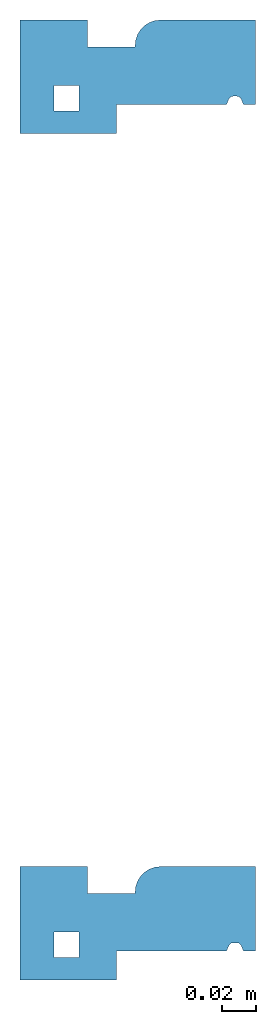
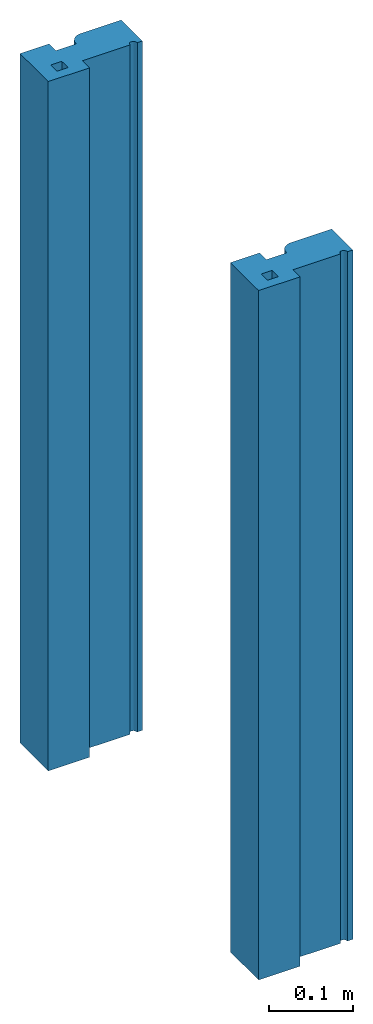
# One storey: 2 columns.
"""IFC4 building model written with IfcOpenShell, lengths in millimetres."""

from ifc_helpers import new_model, entity, si_unit, converted_unit, frame, origin_with_axes, origin_2d_with_axis, place, context, subcontext, project, spatial, line, arc, indexed_curve, outline, extrude, material, material_profile, profile_set, profile_usage, type_object, element, save


model = new_model("IFC4")

# Units and contexts
model_context = context("Model", 3, precision=1e-05, world=origin_with_axes())
plan_context = context("Plan", 2, precision=1e-05, world=origin_2d_with_axis())
body_context = subcontext(model_context, "Body", "Model", "MODEL_VIEW")
ifc_project = project(units=[converted_unit("PLANEANGLEUNIT", "degree", entity("IfcReal", 0.0174532925199433), si_unit("PLANEANGLEUNIT", "RADIAN"), dimensions=[0, 0, 0, 0, 0, 0, 0]), si_unit("AREAUNIT", "SQUARE_METRE"), si_unit("VOLUMEUNIT", "CUBIC_METRE"), si_unit("LENGTHUNIT", "METRE", prefix="MILLI")], contexts=[model_context, plan_context])

# Site, building, storey
site_placement = place(None, origin_with_axes())
site = spatial("IfcSite", under=ifc_project, at=site_placement)
building_placement = place(site_placement, origin_with_axes())
building = spatial("IfcBuilding", under=site, at=building_placement, Name="Building")
storey_placement = place(building_placement, origin_with_axes())
storey = spatial("IfcBuildingStorey", under=building, at=storey_placement, Name="Storey")

# Columns
ifc_material = material()
ifc_material_profile = material_profile(ifc_material, outline(indexed_curve([(122.000008821487, 17.000000923872), (57.0000037550926, 17.000000923872), (57.0000037550926, 0.0), (0.0, 0.0), (0.0, 67.0000016689301), (39.99999538064, 67.0000016689301), (39.99999538064, 51.000002771616), (67.9999962449074, 51.000002771616), (67.9999962449074, 52.0000010728836), (72.3933950066566, 62.6066029071808), (82.9999968409538, 67.0000016689301), (138.999998569489, 67.0000016689301), (138.999998569489, 17.000000923872), (131.999999284744, 17.000000923872), (130.754321813583, 20.1141759753227), (129.650771617889, 21.4842073619366), (127.968892455101, 22.0000017434359), (126.031100749969, 22.0000017434359), (124.3492141366, 21.4842054992914), (123.245671391487, 20.1141722500324), (34.9777266383171, 28.312548995018), (19.9777260422707, 28.312548995018), (19.9777260422707, 13.3125483989716), (34.9777266383171, 13.3125483989716)], segments=[line(5, 4), line(4, 3), line(3, 2), line(2, 1), line(1, 20), arc(20, 19, 18), line(18, 17), arc(17, 16, 15), line(15, 14), line(14, 13), line(13, 12), line(12, 11), arc(11, 10, 9), line(9, 8), line(8, 7), line(7, 6), line(6, 5)], self_intersect=False), holes=[indexed_curve([(122.000008821487, 17.000000923872), (57.0000037550926, 17.000000923872), (57.0000037550926, 0.0), (0.0, 0.0), (0.0, 67.0000016689301), (39.99999538064, 67.0000016689301), (39.99999538064, 51.000002771616), (67.9999962449074, 51.000002771616), (67.9999962449074, 52.0000010728836), (72.3933950066566, 62.6066029071808), (82.9999968409538, 67.0000016689301), (138.999998569489, 67.0000016689301), (138.999998569489, 17.000000923872), (131.999999284744, 17.000000923872), (130.754321813583, 20.1141759753227), (129.650771617889, 21.4842073619366), (127.968892455101, 22.0000017434359), (126.031100749969, 22.0000017434359), (124.3492141366, 21.4842054992914), (123.245671391487, 20.1141722500324), (34.9777266383171, 28.312548995018), (19.9777260422707, 28.312548995018), (19.9777260422707, 13.3125483989716), (34.9777266383171, 13.3125483989716)], segments=[line(22, 23), line(23, 24), line(24, 21), line(21, 22)], self_intersect=False)]))
ifc_profile_set = profile_set([ifc_material_profile])
ifc_profile_usage_1 = profile_usage(ifc_profile_set, cardinal=5)
column_type = type_object("IfcColumnType", PredefinedType="COLUMN", material=ifc_profile_set)
column_1_placement = place(storey_placement, origin_with_axes())
element("IfcColumn", 1, at=column_1_placement, inside=storey, type_object=column_type, material=ifc_profile_usage_1, Name="Column", context=body_context, shape_type="SweptSolid", body=[
    extrude(outline(indexed_curve([(122.000008821487, 17.000000923872), (57.0000037550926, 17.000000923872), (57.0000037550926, 0.0), (0.0, 0.0), (0.0, 67.0000016689301), (39.99999538064, 67.0000016689301), (39.99999538064, 51.000002771616), (67.9999962449074, 51.000002771616), (67.9999962449074, 52.0000010728836), (72.3933950066566, 62.6066029071808), (82.9999968409538, 67.0000016689301), (138.999998569489, 67.0000016689301), (138.999998569489, 17.000000923872), (131.999999284744, 17.000000923872), (130.754321813583, 20.1141759753227), (129.650771617889, 21.4842073619366), (127.968892455101, 22.0000017434359), (126.031100749969, 22.0000017434359), (124.3492141366, 21.4842054992914), (123.245671391487, 20.1141722500324), (34.9777266383171, 28.312548995018), (19.9777260422707, 28.312548995018), (19.9777260422707, 13.3125483989716), (34.9777266383171, 13.3125483989716)], segments=[line(5, 4), line(4, 3), line(3, 2), line(2, 1), line(1, 20), arc(20, 19, 18), line(18, 17), arc(17, 16, 15), line(15, 14), line(14, 13), line(13, 12), line(12, 11), arc(11, 10, 9), line(9, 8), line(8, 7), line(7, 6), line(6, 5)], self_intersect=False), holes=[indexed_curve([(122.000008821487, 17.000000923872), (57.0000037550926, 17.000000923872), (57.0000037550926, 0.0), (0.0, 0.0), (0.0, 67.0000016689301), (39.99999538064, 67.0000016689301), (39.99999538064, 51.000002771616), (67.9999962449074, 51.000002771616), (67.9999962449074, 52.0000010728836), (72.3933950066566, 62.6066029071808), (82.9999968409538, 67.0000016689301), (138.999998569489, 67.0000016689301), (138.999998569489, 17.000000923872), (131.999999284744, 17.000000923872), (130.754321813583, 20.1141759753227), (129.650771617889, 21.4842073619366), (127.968892455101, 22.0000017434359), (126.031100749969, 22.0000017434359), (124.3492141366, 21.4842054992914), (123.245671391487, 20.1141722500324), (34.9777266383171, 28.312548995018), (19.9777260422707, 28.312548995018), (19.9777260422707, 13.3125483989716), (34.9777266383171, 13.3125483989716)], segments=[line(22, 23), line(23, 24), line(24, 21), line(21, 22)], self_intersect=False)]), origin_with_axes(), (0.0, 0.0, 1.0), 999.999940395353),
])
ifc_profile_usage_2 = profile_usage(ifc_profile_set, cardinal=5)
column_2_placement = place(storey_placement, frame((0.0, -500.0, 0.0), z_axis=(0.0, 0.0, 1.0), x_axis=(1.0, 0.0, 0.0)))
element("IfcColumn", 2, at=column_2_placement, inside=storey, type_object=column_type, material=ifc_profile_usage_2, Name="Column", context=body_context, shape_type="SweptSolid", body=[
    extrude(outline(indexed_curve([(122.000008821487, 17.000000923872), (57.0000037550926, 17.000000923872), (57.0000037550926, 0.0), (0.0, 0.0), (0.0, 67.0000016689301), (39.99999538064, 67.0000016689301), (39.99999538064, 51.000002771616), (67.9999962449074, 51.000002771616), (67.9999962449074, 52.0000010728836), (72.3933950066566, 62.6066029071808), (82.9999968409538, 67.0000016689301), (138.999998569489, 67.0000016689301), (138.999998569489, 17.000000923872), (131.999999284744, 17.000000923872), (130.754321813583, 20.1141759753227), (129.650771617889, 21.4842073619366), (127.968892455101, 22.0000017434359), (126.031100749969, 22.0000017434359), (124.3492141366, 21.4842054992914), (123.245671391487, 20.1141722500324), (34.9777266383171, 28.312548995018), (19.9777260422707, 28.312548995018), (19.9777260422707, 13.3125483989716), (34.9777266383171, 13.3125483989716)], segments=[line(5, 4), line(4, 3), line(3, 2), line(2, 1), line(1, 20), arc(20, 19, 18), line(18, 17), arc(17, 16, 15), line(15, 14), line(14, 13), line(13, 12), line(12, 11), arc(11, 10, 9), line(9, 8), line(8, 7), line(7, 6), line(6, 5)], self_intersect=False), holes=[indexed_curve([(122.000008821487, 17.000000923872), (57.0000037550926, 17.000000923872), (57.0000037550926, 0.0), (0.0, 0.0), (0.0, 67.0000016689301), (39.99999538064, 67.0000016689301), (39.99999538064, 51.000002771616), (67.9999962449074, 51.000002771616), (67.9999962449074, 52.0000010728836), (72.3933950066566, 62.6066029071808), (82.9999968409538, 67.0000016689301), (138.999998569489, 67.0000016689301), (138.999998569489, 17.000000923872), (131.999999284744, 17.000000923872), (130.754321813583, 20.1141759753227), (129.650771617889, 21.4842073619366), (127.968892455101, 22.0000017434359), (126.031100749969, 22.0000017434359), (124.3492141366, 21.4842054992914), (123.245671391487, 20.1141722500324), (34.9777266383171, 28.312548995018), (19.9777260422707, 28.312548995018), (19.9777260422707, 13.3125483989716), (34.9777266383171, 13.3125483989716)], segments=[line(22, 23), line(23, 24), line(24, 21), line(21, 22)], self_intersect=False)]), origin_with_axes(), (0.0, 0.0, 1.0), 999.999225139318),
])

save(model, "model.ifc")
